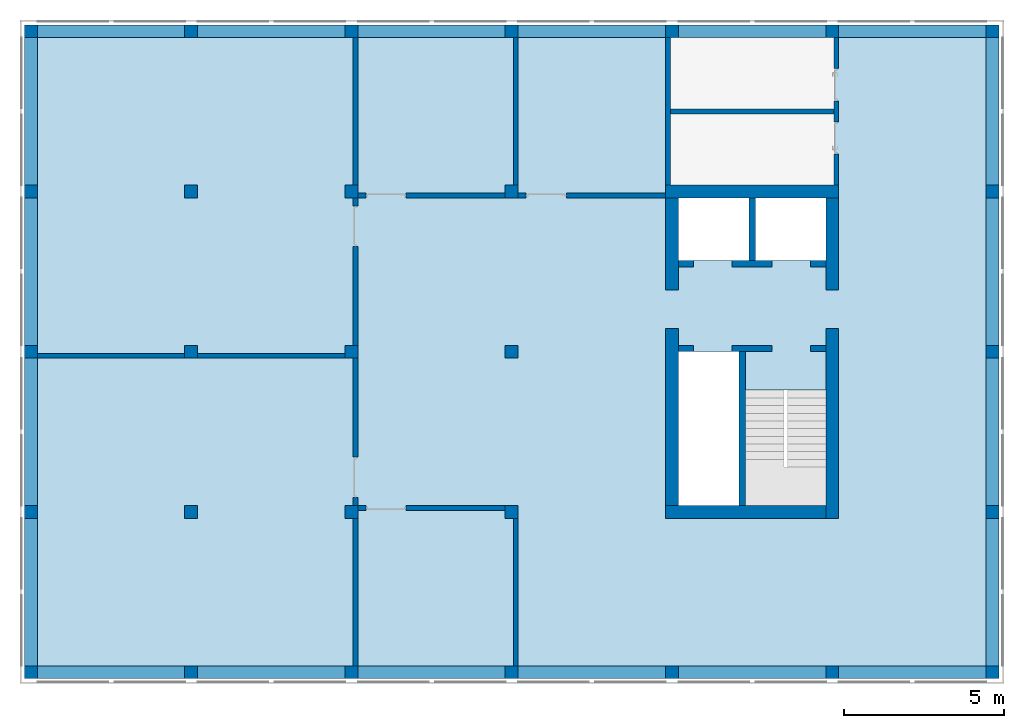
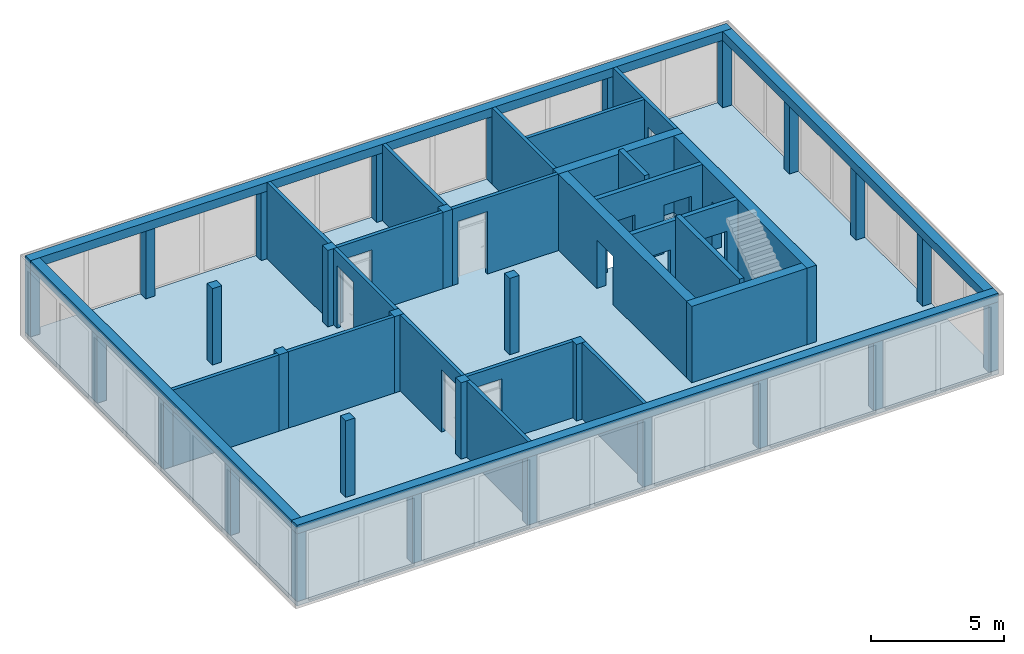
# One storey, part 1 of 6: 29 columns, 22 walls, 4 beams, 1 slab, 16 openings.
"""IFC2X3 building model written with IfcOpenShell, lengths in metres."""

import ifcopenshell
import ifcopenshell.guid

model = None  # the IFC model being written
_history = None  # IfcOwnerHistory: only IFC2X3 demands one
_inside = {}  # id of a spatial element -> (the spatial element, [elements in it])
_under = {}  # id of a project, library or spatial element -> (it, [spatial elements below it])
_declared = {}  # id of a project -> (the project, [libraries it declares])
_typed = {}  # id of a type object -> (the type object, [elements of that type])
_made_of = {}  # id of a material, layer set ... -> (it, [elements and type objects made of it])


def new_model(schema):
    """Start an empty IFC model of exactly this schema.

    Asked for "IFC4X3", IfcOpenShell would pick the latest addendum, in which some entities
    have other attributes; the version numbers below select the first issue.
    IFC2X3 requires an IfcOwnerHistory on every rooted entity: one is made here for all.
    """
    global model, _history
    if schema == "IFC4X3":
        model = ifcopenshell.file(schema_version=(4, 3, 0, 0))
    else:
        model = ifcopenshell.file(schema=schema)
    _inside.clear()
    _under.clear()
    _declared.clear()
    _typed.clear()
    _made_of.clear()
    _history = None
    if model.schema == "IFC2X3":
        org = make("IfcOrganization", Name="unknown")
        user = make(
            "IfcPersonAndOrganization",
            ThePerson=make("IfcPerson", FamilyName="unknown"),
            TheOrganization=org,
        )
        app = make(
            "IfcApplication",
            ApplicationDeveloper=org,
            Version="unknown",
            ApplicationFullName="unknown",
            ApplicationIdentifier="unknown",
        )
        _history = make(
            "IfcOwnerHistory",
            OwningUser=user,
            OwningApplication=app,
            ChangeAction="ADDED",
            CreationDate=0,
        )
    return model


def make(cls, **values):
    """One entity of the class cls with the attributes given. An attribute that is None is left unset."""
    return model.create_entity(
        cls, **{name: value for name, value in values.items() if value is not None}
    )


def entity(cls, *values):
    """Any entity or typed value of the class cls, its attributes in the order of the schema. None: left unset."""
    e = model.create_entity(cls)
    for i, value in enumerate(values):
        if value is not None:
            e[i] = value
    return e


def rooted(cls, **values):
    """An entity with a GlobalId (a new one), such as an element, a storey or a relation."""
    return make(cls, GlobalId=ifcopenshell.guid.new(), OwnerHistory=_history, **values)


def si_unit(unit_type, name, prefix=None):
    """IfcSIUnit, for example si_unit("LENGTHUNIT", "METRE", prefix="MILLI")."""
    return make("IfcSIUnit", UnitType=unit_type, Prefix=prefix, Name=name)


def converted_unit(unit_type, name, factor, base, dimensions=None, offset=None):
    """IfcConversionBasedUnit, such as the inch: factor (a typed value) times the base unit."""
    return make(
        "IfcConversionBasedUnit"
        if offset is None
        else "IfcConversionBasedUnitWithOffset",
        ConversionOffset=offset,
        Dimensions=None
        if dimensions is None
        else entity("IfcDimensionalExponents", *dimensions),
        UnitType=unit_type,
        Name=name,
        ConversionFactor=make(
            "IfcMeasureWithUnit", ValueComponent=factor, UnitComponent=base
        ),
    )


def assignment(units):
    """IfcUnitAssignment: the units of a project."""
    return None if units is None else make("IfcUnitAssignment", Units=units)


def point(xyz):
    """IfcCartesianPoint."""
    return None if xyz is None else make("IfcCartesianPoint", Coordinates=xyz)


def direction(xyz):
    """IfcDirection."""
    return None if xyz is None else make("IfcDirection", DirectionRatios=xyz)


def frame(location, z_axis=None, x_axis=None):
    """IfcAxis2Placement3D, a coordinate frame: its origin and axes. An axis left out is left unset."""
    return make(
        "IfcAxis2Placement3D",
        Location=point(location),
        Axis=direction(z_axis),
        RefDirection=direction(x_axis),
    )


def frame_2d(location, x_axis=None):
    """IfcAxis2Placement2D, a coordinate frame in the plane: its origin and x axis."""
    return make(
        "IfcAxis2Placement2D", Location=point(location), RefDirection=direction(x_axis)
    )


def origin():
    """The frame at (0, 0, 0) with its axes left unset."""
    return frame((0.0, 0.0, 0.0))


def origin_with_axes():
    """The frame at (0, 0, 0) with the z axis (0, 0, 1) and the x axis (1, 0, 0) written out."""
    return frame((0.0, 0.0, 0.0), z_axis=(0.0, 0.0, 1.0), x_axis=(1.0, 0.0, 0.0))


def place(relative_to, where):
    """IfcLocalPlacement: puts the frame where relative to a parent placement (None: the world)."""
    return make(
        "IfcLocalPlacement", PlacementRelTo=relative_to, RelativePlacement=where
    )


def context(
    kind, dimensions, precision=None, world=None, true_north=None, identifier=None
):
    """IfcGeometricRepresentationContext, for example the 3D "Model" context."""
    return make(
        "IfcGeometricRepresentationContext",
        ContextIdentifier=identifier,
        ContextType=kind,
        CoordinateSpaceDimension=dimensions,
        Precision=precision,
        WorldCoordinateSystem=world,
        TrueNorth=true_north,
    )


def subcontext(parent, identifier, kind, view, scale=None):
    """IfcGeometricRepresentationSubContext, for example "Body" below "Model"."""
    return make(
        "IfcGeometricRepresentationSubContext",
        ContextIdentifier=identifier,
        ContextType=kind,
        ParentContext=parent,
        TargetScale=scale,
        TargetView=view,
    )


def project(units=None, contexts=None):
    """IfcProject with its units and contexts."""
    return rooted(
        "IfcProject",
        Name="project",
        RepresentationContexts=contexts,
        UnitsInContext=assignment(units),
    )


def spatial(cls, under=None, at=None, **own):
    """A site, building, storey or space (cls), placed at a placement, below another one or the project."""
    s = rooted(cls, ObjectPlacement=at, **own)
    if under is not None:
        _under.setdefault(under.id(), (under, []))[1].append(s)
    return s


def polyline(points):
    """IfcPolyline through the points."""
    return make("IfcPolyline", Points=[point(p) for p in points])


def profile(cls, at=None, kind="AREA", **sizes):
    """A parametric profile (cls). Its sizes go by their IFC names, for example OverallWidth=200.0."""
    return make(cls, ProfileType=kind, Position=at, **sizes)


def rectangle(**sizes):
    """IfcRectangleProfileDef."""
    return profile("IfcRectangleProfileDef", **sizes)


def outline(outer, holes=None, kind="AREA"):
    """IfcArbitraryClosedProfileDef: a profile drawn as a closed curve; with holes, ...WithVoids."""
    if holes is None:
        return make("IfcArbitraryClosedProfileDef", ProfileType=kind, OuterCurve=outer)
    return make(
        "IfcArbitraryProfileDefWithVoids",
        ProfileType=kind,
        OuterCurve=outer,
        InnerCurves=holes,
    )


def extrude(swept, where, along, depth):
    """IfcExtrudedAreaSolid: the profile swept, set in the frame where, extruded along a direction by depth."""
    return make(
        "IfcExtrudedAreaSolid",
        SweptArea=swept,
        Position=where,
        ExtrudedDirection=direction(along),
        Depth=depth,
    )


def shape(context_of_items, identifier, shape_type, items):
    """IfcShapeRepresentation: the items that make up one representation, for example the "Body"."""
    return make(
        "IfcShapeRepresentation",
        ContextOfItems=context_of_items,
        RepresentationIdentifier=identifier,
        RepresentationType=shape_type,
        Items=items,
    )


def material(Name=None, Category=None):
    """IfcMaterial."""
    return make("IfcMaterial", Name=Name, Category=Category)


def layer(
    of_material, thickness, ventilated=None, Name=None, Category=None, Priority=None
):
    """IfcMaterialLayer: one layer of a wall or slab, of a material (None: an air gap)."""
    return make(
        "IfcMaterialLayer",
        Material=of_material,
        LayerThickness=thickness,
        IsVentilated=ventilated,
        Name=Name,
        Category=Category,
        Priority=Priority,
    )


def layer_set(layers, Name=None):
    """IfcMaterialLayerSet."""
    return make("IfcMaterialLayerSet", MaterialLayers=layers, LayerSetName=Name)


def layer_usage(for_layer_set, set_direction, sense, offset, extent=None):
    """IfcMaterialLayerSetUsage: how a layer set lies in its element."""
    return make(
        "IfcMaterialLayerSetUsage",
        ForLayerSet=for_layer_set,
        LayerSetDirection=set_direction,
        DirectionSense=sense,
        OffsetFromReferenceLine=offset,
        ReferenceExtent=extent,
    )


def made_of(thing, what):
    """Note that an element or type object is made of a material, layer set ...; save() writes the relation."""
    if what is not None:
        _made_of.setdefault(what.id(), (what, []))[1].append(thing)
    return thing


def element(
    cls,
    number,
    at=None,
    inside=None,
    cuts=None,
    type_object=None,
    material=None,
    context=None,
    identifier="Body",
    shape_type=None,
    held_by="IfcProductDefinitionShape",
    body=None,
    shapes=None,
    **own,
):
    """One element of the class cls, such as IfcWall. Its Tag is "e" and its number.

    at: its placement. inside: the storey or other place that contains it. cuts: it is an
    opening in that element (IfcRelVoidsElement). A single representation is given by context,
    identifier, shape_type and body (its items); several are given by shapes. held_by: the class
    of the entity that holds the representations. save() writes the other relations.
    """
    e = rooted(cls, Tag="e%d" % number, ObjectPlacement=at, **own)
    if body is not None:
        shapes = [shape(context, identifier, shape_type, body)]
    if shapes is not None:
        e.Representation = make(held_by, Representations=shapes)
    if inside is not None:
        _inside.setdefault(inside.id(), (inside, []))[1].append(e)
    if cuts is not None:
        rooted(
            "IfcRelVoidsElement", RelatingBuildingElement=cuts, RelatedOpeningElement=e
        )
    if type_object is not None:
        _typed.setdefault(type_object.id(), (type_object, []))[1].append(e)
    return made_of(e, material)


def aggregate(whole, parts):
    """IfcRelAggregates: a whole, such as a stair, and the parts it consists of."""
    return rooted("IfcRelAggregates", RelatingObject=whole, RelatedObjects=parts)


def save(model, path):
    """Write the relations noted so far, then the file.

    IfcRelAggregates (storeys below a building ...), IfcRelContainedInSpatialStructure (elements
    in a storey), IfcRelDefinesByType, IfcRelAssociatesMaterial and IfcRelDeclares: one each for
    every whole, place, type object, material and project.
    """
    for whole, parts in _under.values():
        aggregate(whole, parts)
    for where, things in _inside.values():
        rooted(
            "IfcRelContainedInSpatialStructure",
            RelatedElements=things,
            RelatingStructure=where,
        )
    for kind, things in _typed.values():
        rooted("IfcRelDefinesByType", RelatedObjects=things, RelatingType=kind)
    for what, things in _made_of.values():
        rooted("IfcRelAssociatesMaterial", RelatedObjects=things, RelatingMaterial=what)
    for by, libraries in _declared.values():
        rooted("IfcRelDeclares", RelatingContext=by, RelatedDefinitions=libraries)
    model.write(path)


model = new_model("IFC2X3")

# Units and contexts
model_context = context("Model", 3, precision=1e-05, world=origin())
body_context = subcontext(model_context, "Body", "Model", "MODEL_VIEW")
ifc_project = project(units=[si_unit("LENGTHUNIT", "METRE"), si_unit("AREAUNIT", "SQUARE_METRE"), si_unit("VOLUMEUNIT", "CUBIC_METRE"), si_unit("MASSUNIT", "GRAM", prefix="KILO"), converted_unit("PLANEANGLEUNIT", "DEGREE", entity("IfcPlaneAngleMeasure", 0.0174532925199433), si_unit("PLANEANGLEUNIT", "RADIAN"), dimensions=[0, 0, 0, 0, 0, 0, 0])], contexts=[model_context])

# Site, building, storey
site_placement = place(None, origin())
site = spatial("IfcSite", under=ifc_project, at=site_placement, CompositionType="ELEMENT")
building_placement = place(site_placement, origin())
building = spatial("IfcBuilding", under=site, at=building_placement, CompositionType="ELEMENT")
storey_placement = place(building_placement, frame((0.0, 0.0, 8.6)))
storey = spatial("IfcBuildingStorey", under=building, at=storey_placement, Name="2. Obergeschoss", CompositionType="ELEMENT", Elevation=8.6)

# Columns
ifc_material_1 = material(Name="C30/37")
column_1_placement = place(storey_placement, frame((5.0, 5.0, 0.0)))
element("IfcColumn", 1, at=column_1_placement, inside=storey, material=ifc_material_1, context=body_context, shape_type="SweptSolid", body=[
    extrude(rectangle(XDim=0.4, YDim=0.4, at=frame_2d((0.2, 0.2), x_axis=(1.0, 0.0))), origin_with_axes(), (0.0, 0.0, 1.0), 3.5),
])
ifc_material_2 = material(Name="C30/37")
column_2_placement = place(storey_placement, frame((10.0, 5.0, 0.0)))
element("IfcColumn", 2, at=column_2_placement, inside=storey, material=ifc_material_2, context=body_context, shape_type="SweptSolid", body=[
    extrude(rectangle(XDim=0.4, YDim=0.4, at=frame_2d((0.2, 0.2), x_axis=(1.0, 0.0))), origin_with_axes(), (0.0, 0.0, 1.0), 3.5),
])
ifc_material_3 = material(Name="C30/37")
column_3_placement = place(storey_placement, frame((5.0, 10.0, 0.0)))
element("IfcColumn", 3, at=column_3_placement, inside=storey, material=ifc_material_3, context=body_context, shape_type="SweptSolid", body=[
    extrude(rectangle(XDim=0.4, YDim=0.4, at=frame_2d((0.2, 0.2), x_axis=(1.0, 0.0))), origin_with_axes(), (0.0, 0.0, 1.0), 3.5),
])
ifc_material_4 = material(Name="C30/37")
column_4_placement = place(storey_placement, frame((10.0, 10.0, 0.0)))
element("IfcColumn", 4, at=column_4_placement, inside=storey, material=ifc_material_4, context=body_context, shape_type="SweptSolid", body=[
    extrude(rectangle(XDim=0.4, YDim=0.4, at=frame_2d((0.2, 0.2), x_axis=(1.0, 0.0))), origin_with_axes(), (0.0, 0.0, 1.0), 3.5),
])
ifc_material_5 = material(Name="C30/37")
column_5_placement = place(storey_placement, frame((15.0, 10.0, 0.0)))
element("IfcColumn", 5, at=column_5_placement, inside=storey, material=ifc_material_5, context=body_context, shape_type="SweptSolid", body=[
    extrude(rectangle(XDim=0.4, YDim=0.4, at=frame_2d((0.2, 0.2), x_axis=(1.0, 0.0))), origin_with_axes(), (0.0, 0.0, 1.0), 3.5),
])
ifc_material_6 = material(Name="C30/37")
column_6_placement = place(storey_placement, frame((5.0, 15.0, 0.0)))
element("IfcColumn", 6, at=column_6_placement, inside=storey, material=ifc_material_6, context=body_context, shape_type="SweptSolid", body=[
    extrude(rectangle(XDim=0.4, YDim=0.4, at=frame_2d((0.2, 0.2), x_axis=(1.0, 0.0))), origin_with_axes(), (0.0, 0.0, 1.0), 3.5),
])
ifc_material_7 = material(Name="C30/37")
column_7_placement = place(storey_placement, frame((10.0, 15.0, 0.0)))
element("IfcColumn", 7, at=column_7_placement, inside=storey, material=ifc_material_7, context=body_context, shape_type="SweptSolid", body=[
    extrude(rectangle(XDim=0.4, YDim=0.4, at=frame_2d((0.2, 0.2), x_axis=(1.0, 0.0))), origin_with_axes(), (0.0, 0.0, 1.0), 3.5),
])
ifc_material_8 = material(Name="C30/37")
column_8_placement = place(storey_placement, frame((15.0, 15.0, 0.0)))
element("IfcColumn", 8, at=column_8_placement, inside=storey, material=ifc_material_8, context=body_context, shape_type="SweptSolid", body=[
    extrude(rectangle(XDim=0.4, YDim=0.4, at=frame_2d((0.2, 0.2), x_axis=(1.0, 0.0))), origin_with_axes(), (0.0, 0.0, 1.0), 3.5),
])
ifc_material_9 = material(Name="C30/37")
column_9_placement = place(storey_placement, frame((15.0, 5.0, 0.0)))
element("IfcColumn", 9, at=column_9_placement, inside=storey, material=ifc_material_9, context=body_context, shape_type="SweptSolid", body=[
    extrude(rectangle(XDim=0.4, YDim=0.4, at=frame_2d((0.2, 0.2), x_axis=(1.0, 0.0))), origin_with_axes(), (0.0, 0.0, 1.0), 3.5),
])
ifc_material_10 = material(Name="C30/37")
column_10_placement = place(storey_placement, frame((30.0, 5.0, 0.0)))
element("IfcColumn", 10, at=column_10_placement, inside=storey, material=ifc_material_10, context=body_context, shape_type="SweptSolid", body=[
    extrude(rectangle(XDim=0.4, YDim=0.4, at=frame_2d((0.2, 0.2), x_axis=(1.0, 0.0))), origin_with_axes(), (0.0, 0.0, 1.0), 3.1),
])
ifc_material_11 = material(Name="C30/37")
column_11_placement = place(storey_placement, frame((30.0, 10.0, 0.0)))
element("IfcColumn", 11, at=column_11_placement, inside=storey, material=ifc_material_11, context=body_context, shape_type="SweptSolid", body=[
    extrude(rectangle(XDim=0.4, YDim=0.4, at=frame_2d((0.2, 0.2), x_axis=(1.0, 0.0))), origin_with_axes(), (0.0, 0.0, 1.0), 3.1),
])
ifc_material_12 = material(Name="C30/37")
column_12_placement = place(storey_placement, frame((30.0, 15.0, 0.0)))
element("IfcColumn", 12, at=column_12_placement, inside=storey, material=ifc_material_12, context=body_context, shape_type="SweptSolid", body=[
    extrude(rectangle(XDim=0.4, YDim=0.4, at=frame_2d((0.2, 0.2), x_axis=(1.0, 0.0))), origin_with_axes(), (0.0, 0.0, 1.0), 3.1),
])
ifc_material_13 = material(Name="C30/37")
column_13_placement = place(storey_placement, frame((30.0, 20.0, 0.0)))
element("IfcColumn", 13, at=column_13_placement, inside=storey, material=ifc_material_13, context=body_context, shape_type="SweptSolid", body=[
    extrude(rectangle(XDim=0.4, YDim=0.4, at=frame_2d((0.2, 0.2), x_axis=(1.0, 0.0))), origin_with_axes(), (0.0, 0.0, 1.0), 3.1),
])
ifc_material_14 = material(Name="C30/37")
column_14_placement = place(storey_placement, frame((30.0, -2.8421709430404e-17, 0.0)))
element("IfcColumn", 14, at=column_14_placement, inside=storey, material=ifc_material_14, context=body_context, shape_type="SweptSolid", body=[
    extrude(rectangle(XDim=0.4, YDim=0.4, at=frame_2d((0.2, 0.2), x_axis=(1.0, 0.0))), origin_with_axes(), (0.0, 0.0, 1.0), 3.1),
])
ifc_material_15 = material(Name="C30/37")
column_15_placement = place(storey_placement, frame((25.0, 20.0, 0.0)))
element("IfcColumn", 15, at=column_15_placement, inside=storey, material=ifc_material_15, context=body_context, shape_type="SweptSolid", body=[
    extrude(rectangle(XDim=0.4, YDim=0.4, at=frame_2d((0.2, 0.2), x_axis=(1.0, 0.0))), origin_with_axes(), (0.0, 0.0, 1.0), 3.1),
])
ifc_material_16 = material(Name="C30/37")
column_16_placement = place(storey_placement, frame((5.0, 20.0, 0.0)))
element("IfcColumn", 16, at=column_16_placement, inside=storey, material=ifc_material_16, context=body_context, shape_type="SweptSolid", body=[
    extrude(rectangle(XDim=0.4, YDim=0.4, at=frame_2d((0.2, 0.2), x_axis=(1.0, 0.0))), origin_with_axes(), (0.0, 0.0, 1.0), 3.1),
])
ifc_material_17 = material(Name="C30/37")
column_17_placement = place(storey_placement, frame((10.0, 20.0, 0.0)))
element("IfcColumn", 17, at=column_17_placement, inside=storey, material=ifc_material_17, context=body_context, shape_type="SweptSolid", body=[
    extrude(rectangle(XDim=0.4, YDim=0.4, at=frame_2d((0.2, 0.2), x_axis=(1.0, 0.0))), origin_with_axes(), (0.0, 0.0, 1.0), 3.1),
])
ifc_material_18 = material(Name="C30/37")
column_18_placement = place(storey_placement, frame((15.0, 20.0, 0.0)))
element("IfcColumn", 18, at=column_18_placement, inside=storey, material=ifc_material_18, context=body_context, shape_type="SweptSolid", body=[
    extrude(rectangle(XDim=0.4, YDim=0.4, at=frame_2d((0.2, 0.2), x_axis=(1.0, 0.0))), origin_with_axes(), (0.0, 0.0, 1.0), 3.1),
])
ifc_material_19 = material(Name="C30/37")
column_19_placement = place(storey_placement, frame((20.0, 20.0, 0.0)))
element("IfcColumn", 19, at=column_19_placement, inside=storey, material=ifc_material_19, context=body_context, shape_type="SweptSolid", body=[
    extrude(rectangle(XDim=0.4, YDim=0.4, at=frame_2d((0.2, 0.2), x_axis=(1.0, 0.0))), origin_with_axes(), (0.0, 0.0, 1.0), 3.1),
])
ifc_material_20 = material(Name="C30/37")
column_20_placement = place(storey_placement, frame((0.0, 20.0, 0.0)))
element("IfcColumn", 20, at=column_20_placement, inside=storey, material=ifc_material_20, context=body_context, shape_type="SweptSolid", body=[
    extrude(rectangle(XDim=0.4, YDim=0.4, at=frame_2d((0.2, 0.2), x_axis=(1.0, 0.0))), origin_with_axes(), (0.0, 0.0, 1.0), 3.1),
])
ifc_material_21 = material(Name="C30/37")
column_21_placement = place(storey_placement, frame((0.0, 5.0, 0.0)))
element("IfcColumn", 21, at=column_21_placement, inside=storey, material=ifc_material_21, context=body_context, shape_type="SweptSolid", body=[
    extrude(rectangle(XDim=0.4, YDim=0.4, at=frame_2d((0.2, 0.2), x_axis=(1.0, 0.0))), origin_with_axes(), (0.0, 0.0, 1.0), 3.1),
])
ifc_material_22 = material(Name="C30/37")
column_22_placement = place(storey_placement, frame((0.0, 10.0, 0.0)))
element("IfcColumn", 22, at=column_22_placement, inside=storey, material=ifc_material_22, context=body_context, shape_type="SweptSolid", body=[
    extrude(rectangle(XDim=0.4, YDim=0.4, at=frame_2d((0.2, 0.2), x_axis=(1.0, 0.0))), origin_with_axes(), (0.0, 0.0, 1.0), 3.1),
])
ifc_material_23 = material(Name="C30/37")
column_23_placement = place(storey_placement, frame((0.0, 15.0, 0.0)))
element("IfcColumn", 23, at=column_23_placement, inside=storey, material=ifc_material_23, context=body_context, shape_type="SweptSolid", body=[
    extrude(rectangle(XDim=0.4, YDim=0.4, at=frame_2d((0.2, 0.2), x_axis=(1.0, 0.0))), origin_with_axes(), (0.0, 0.0, 1.0), 3.1),
])
ifc_material_24 = material(Name="C30/37")
column_24_placement = place(storey_placement, origin())
element("IfcColumn", 24, at=column_24_placement, inside=storey, material=ifc_material_24, context=body_context, shape_type="SweptSolid", body=[
    extrude(rectangle(XDim=0.4, YDim=0.4, at=frame_2d((0.2, 0.2), x_axis=(1.0, 0.0))), origin_with_axes(), (0.0, 0.0, 1.0), 3.1),
])
ifc_material_25 = material(Name="C30/37")
column_25_placement = place(storey_placement, frame((5.0, 0.0, 0.0)))
element("IfcColumn", 25, at=column_25_placement, inside=storey, material=ifc_material_25, context=body_context, shape_type="SweptSolid", body=[
    extrude(rectangle(XDim=0.4, YDim=0.4, at=frame_2d((0.2, 0.2), x_axis=(1.0, 0.0))), origin_with_axes(), (0.0, 0.0, 1.0), 3.1),
])
ifc_material_26 = material(Name="C30/37")
column_26_placement = place(storey_placement, frame((10.0, 0.0, 0.0)))
element("IfcColumn", 26, at=column_26_placement, inside=storey, material=ifc_material_26, context=body_context, shape_type="SweptSolid", body=[
    extrude(rectangle(XDim=0.4, YDim=0.4, at=frame_2d((0.2, 0.2), x_axis=(1.0, 0.0))), origin_with_axes(), (0.0, 0.0, 1.0), 3.1),
])
ifc_material_27 = material(Name="C30/37")
column_27_placement = place(storey_placement, frame((15.0, 0.0, 0.0)))
element("IfcColumn", 27, at=column_27_placement, inside=storey, material=ifc_material_27, context=body_context, shape_type="SweptSolid", body=[
    extrude(rectangle(XDim=0.4, YDim=0.4, at=frame_2d((0.2, 0.2), x_axis=(1.0, 0.0))), origin_with_axes(), (0.0, 0.0, 1.0), 3.1),
])
ifc_material_28 = material(Name="C30/37")
column_28_placement = place(storey_placement, frame((20.0, 0.0, 0.0)))
element("IfcColumn", 28, at=column_28_placement, inside=storey, material=ifc_material_28, context=body_context, shape_type="SweptSolid", body=[
    extrude(rectangle(XDim=0.4, YDim=0.4, at=frame_2d((0.2, 0.2), x_axis=(1.0, 0.0))), origin_with_axes(), (0.0, 0.0, 1.0), 3.1),
])
ifc_material_29 = material(Name="C30/37")
column_29_placement = place(storey_placement, frame((25.0, 0.0, 0.0)))
element("IfcColumn", 29, at=column_29_placement, inside=storey, material=ifc_material_29, context=body_context, shape_type="SweptSolid", body=[
    extrude(rectangle(XDim=0.4, YDim=0.4, at=frame_2d((0.2, 0.2), x_axis=(1.0, 0.0))), origin_with_axes(), (0.0, 0.0, 1.0), 3.1),
])

# Beams
ifc_material_30 = material(Name="C30/37")
beam_1_placement = place(storey_placement, frame((-2.8421709430404e-17, 20.0, 3.1)))
element("IfcBeam", 30, at=beam_1_placement, inside=storey, material=ifc_material_30, context=body_context, shape_type="SweptSolid", body=[
    extrude(rectangle(XDim=0.4, YDim=0.4, at=frame_2d((0.2, 0.2), x_axis=(1.0, 0.0))), frame((0.0, 0.0, 0.0), z_axis=(1.0, 0.0, 0.0), x_axis=(0.0, 1.0, 0.0)), (0.0, 0.0, 1.0), 30.4),
])
ifc_material_31 = material(Name="C30/37")
beam_2_placement = place(storey_placement, frame((2.95817792030736e-17, 2.8421709430404e-17, 3.1), z_axis=(0.0, 0.0, 1.0), x_axis=(1.0, -1.86984930463184e-18, 0.0)))
element("IfcBeam", 31, at=beam_2_placement, inside=storey, material=ifc_material_31, context=body_context, shape_type="SweptSolid", body=[
    extrude(rectangle(XDim=0.4, YDim=0.4, at=frame_2d((0.2, 0.2), x_axis=(1.0, 0.0))), frame((0.0, 0.0, 0.0), z_axis=(1.0, 0.0, 0.0), x_axis=(0.0, 1.0, 0.0)), (0.0, 0.0, 1.0), 30.4),
])
ifc_material_32 = material(Name="C30/37")
beam_3_placement = place(storey_placement, frame((30.4, 0.4, 3.1), z_axis=(0.0, 0.0, 1.0), x_axis=(0.0, 1.0, 0.0)))
element("IfcBeam", 32, at=beam_3_placement, inside=storey, material=ifc_material_32, context=body_context, shape_type="SweptSolid", body=[
    extrude(rectangle(XDim=0.4, YDim=0.4, at=frame_2d((0.2, 0.2), x_axis=(1.0, 0.0))), frame((0.0, 0.0, 0.0), z_axis=(1.0, 0.0, 0.0), x_axis=(0.0, 1.0, 0.0)), (0.0, 0.0, 1.0), 19.6),
])
ifc_material_33 = material(Name="C30/37")
beam_4_placement = place(storey_placement, frame((-2.8421709430404e-17, 20.0, 3.1), z_axis=(0.0, 0.0, 1.0), x_axis=(2.90017443167388e-18, -1.0, 0.0)))
element("IfcBeam", 33, at=beam_4_placement, inside=storey, material=ifc_material_33, context=body_context, shape_type="SweptSolid", body=[
    extrude(rectangle(XDim=0.4, YDim=0.4, at=frame_2d((0.2, 0.2), x_axis=(1.0, 0.0))), frame((0.0, 0.0, 0.0), z_axis=(1.0, 0.0, 0.0), x_axis=(0.0, 1.0, 0.0)), (0.0, 0.0, 1.0), 19.6),
])

# Slab, openings
ifc_material_34 = material(Name="C25/30")
slab_placement = place(storey_placement, frame((0.0, 0.0, -0.2)))
slab = element("IfcSlab", 34, at=slab_placement, inside=storey, material=ifc_material_34, Name="Geschossdecke", PredefinedType="FLOOR", context=body_context, shape_type="SweptSolid", body=[
    extrude(rectangle(XDim=30.4, YDim=20.4, at=frame_2d((15.2, 10.2), x_axis=(1.0, 0.0))), origin_with_axes(), (0.0, 0.0, 1.0), 0.2),
])
opening_1_placement = place(slab_placement, frame((22.5, 5.4, 0.0)))
element("IfcOpeningElement", 35, at=opening_1_placement, cuts=slab, ObjectType="Opening", context=body_context, shape_type="SweptSolid", body=[
    extrude(rectangle(XDim=3.6, YDim=2.5, at=frame_2d((0.0, 0.0), x_axis=(0.0, -1.0))), frame((1.25, 1.8, 0.0), z_axis=(0.0, 0.0, 1.0), x_axis=(1.0, 0.0, 0.0)), (0.0, 0.0, 1.0), 0.2),
])
opening_2_placement = place(slab_placement, frame((20.4, 5.4, 0.0)))
element("IfcOpeningElement", 36, at=opening_2_placement, cuts=slab, ObjectType="Opening", context=body_context, shape_type="SweptSolid", body=[
    extrude(rectangle(XDim=2.1, YDim=4.8, at=frame_2d((1.81898940354586e-15, 0.0), x_axis=(-1.0, 0.0))), frame((1.05, 2.4, 0.0), z_axis=(0.0, 0.0, 1.0), x_axis=(1.0, 0.0, 0.0)), (0.0, 0.0, 1.0), 0.2),
])
opening_3_placement = place(slab_placement, frame((20.4, 13.05, 0.0)))
element("IfcOpeningElement", 37, at=opening_3_placement, cuts=slab, ObjectType="Opening", context=body_context, shape_type="SweptSolid", body=[
    extrude(rectangle(XDim=1.95, YDim=4.6, at=frame_2d((1.81898940354586e-15, 0.0), x_axis=(0.0, -1.0))), frame((2.3, 0.975, 0.0), z_axis=(0.0, 0.0, 1.0), x_axis=(1.0, 0.0, 0.0)), (0.0, 0.0, 1.0), 0.2),
])

# Wall
ifc_material_35 = material(Name="C25/30")
ifc_layer_1 = layer(ifc_material_35, 0.2)
ifc_layer_set_1 = layer_set([ifc_layer_1])
ifc_layer_usage_1 = layer_usage(ifc_layer_set_1, "AXIS2", "POSITIVE", -0.2)
wall_1_placement = place(storey_placement, frame((22.3, 10.2, 0.0), z_axis=(0.0, 0.0, 1.0), x_axis=(0.0, -1.0, 0.0)))
element("IfcWallStandardCase", 38, at=wall_1_placement, inside=storey, material=ifc_layer_usage_1, Name="IW Beton", context=body_context, shape_type="SweptSolid", body=[
    extrude(rectangle(XDim=4.8, YDim=0.2, at=frame_2d((2.4, 0.1), x_axis=(1.0, 0.0))), origin_with_axes(), (0.0, 0.0, 1.0), 3.7),
])

# Wall, openings
ifc_material_36 = material(Name="C25/30")
ifc_layer_2 = layer(ifc_material_36, 0.2)
ifc_layer_set_2 = layer_set([ifc_layer_2])
ifc_layer_usage_2 = layer_usage(ifc_layer_set_2, "AXIS2", "POSITIVE", -0.2)
wall_2_placement = place(storey_placement, frame((25.0, 10.4, 0.0), z_axis=(0.0, 0.0, 1.0), x_axis=(-1.0, 0.0, 0.0)))
wall_2 = element("IfcWallStandardCase", 39, at=wall_2_placement, inside=storey, material=ifc_layer_usage_2, Name="IW Beton", context=body_context, shape_type="SweptSolid", body=[
    extrude(rectangle(XDim=4.6, YDim=0.2, at=frame_2d((2.3, 0.1), x_axis=(1.0, 0.0))), origin_with_axes(), (0.0, 0.0, 1.0), 3.5),
])
opening_4_placement = place(wall_2_placement, frame((1.68, 0.2, 0.0), z_axis=(0.0, -1.0, 0.0), x_axis=(0.0, 0.0, 1.0)))
element("IfcOpeningElement", 40, at=opening_4_placement, cuts=wall_2, ObjectType="Opening", context=body_context, shape_type="SweptSolid", body=[
    extrude(outline(polyline([(0.0, 1.21), (2.21, 1.21), (2.21, 0.0), (0.0, 0.0), (0.0, 1.21)])), origin_with_axes(), (0.0, 0.0, 1.0), 0.2),
])
opening_5_placement = place(wall_2_placement, frame((4.13, 0.2, 0.0), z_axis=(0.0, -1.0, 0.0), x_axis=(0.0, 0.0, 1.0)))
element("IfcOpeningElement", 41, at=opening_5_placement, cuts=wall_2, ObjectType="Opening", context=body_context, shape_type="SweptSolid", body=[
    extrude(outline(polyline([(0.0, 1.21), (2.21, 1.21), (2.21, 0.0), (0.0, 0.0), (0.0, 1.21)])), origin_with_axes(), (0.0, 0.0, 1.0), 0.2),
])

ifc_material_37 = material(Name="C25/30")
ifc_layer_3 = layer(ifc_material_37, 0.2)
ifc_layer_set_3 = layer_set([ifc_layer_3])
ifc_layer_usage_3 = layer_usage(ifc_layer_set_3, "AXIS2", "POSITIVE", -0.2)
wall_3_placement = place(storey_placement, frame((25.0, 13.05, 0.0), z_axis=(0.0, 0.0, 1.0), x_axis=(-1.0, 0.0, 0.0)))
wall_3 = element("IfcWallStandardCase", 42, at=wall_3_placement, inside=storey, material=ifc_layer_usage_3, Name="IW Beton", context=body_context, shape_type="SweptSolid", body=[
    extrude(rectangle(XDim=4.6, YDim=0.2, at=frame_2d((2.3, 0.1), x_axis=(1.0, 0.0))), origin_with_axes(), (0.0, 0.0, 1.0), 3.5),
])
opening_6_placement = place(wall_3_placement, frame((1.68, 0.2, 0.0), z_axis=(0.0, -1.0, 0.0), x_axis=(0.0, 0.0, 1.0)))
element("IfcOpeningElement", 43, at=opening_6_placement, cuts=wall_3, ObjectType="Opening", context=body_context, shape_type="SweptSolid", body=[
    extrude(outline(polyline([(0.0, 1.21), (2.21, 1.21), (2.21, 0.0), (0.0, 0.0), (0.0, 1.21)])), origin_with_axes(), (0.0, 0.0, 1.0), 0.2),
])
opening_7_placement = place(wall_3_placement, frame((4.13, 0.2, 0.0), z_axis=(0.0, -1.0, 0.0), x_axis=(0.0, 0.0, 1.0)))
element("IfcOpeningElement", 44, at=opening_7_placement, cuts=wall_3, ObjectType="Opening", context=body_context, shape_type="SweptSolid", body=[
    extrude(outline(polyline([(0.0, 1.21), (2.21, 1.21), (2.21, 0.0), (0.0, 0.0), (0.0, 1.21)])), origin_with_axes(), (0.0, 0.0, 1.0), 0.2),
])

# Wall
ifc_material_38 = material(Name="C25/30")
ifc_layer_4 = layer(ifc_material_38, 0.2)
ifc_layer_set_4 = layer_set([ifc_layer_4])
ifc_layer_usage_4 = layer_usage(ifc_layer_set_4, "AXIS2", "POSITIVE", -0.2)
wall_4_placement = place(storey_placement, frame((22.6, 15.0, 0.0), z_axis=(0.0, 0.0, 1.0), x_axis=(0.0, -1.0, 0.0)))
element("IfcWallStandardCase", 45, at=wall_4_placement, inside=storey, material=ifc_layer_usage_4, Name="IW Beton", context=body_context, shape_type="SweptSolid", body=[
    extrude(rectangle(XDim=1.95, YDim=0.2, at=frame_2d((0.975, 0.1), x_axis=(1.0, 0.0))), origin_with_axes(), (0.0, 0.0, 1.0), 3.7),
])

# Wall, opening
ifc_material_39 = material(Name="C25/30")
ifc_layer_5 = layer(ifc_material_39, 0.4)
ifc_layer_set_5 = layer_set([ifc_layer_5])
ifc_layer_usage_5 = layer_usage(ifc_layer_set_5, "AXIS2", "POSITIVE", -0.2)
wall_5_placement = place(storey_placement, frame((25.0, 15.0, 0.0), z_axis=(0.0, 0.0, 1.0), x_axis=(0.0, -1.0, 0.0)))
wall_5 = element("IfcWallStandardCase", 46, at=wall_5_placement, inside=storey, material=ifc_layer_usage_5, context=body_context, shape_type="SweptSolid", body=[
    extrude(rectangle(XDim=10.0, YDim=0.4, at=frame_2d((5.0, 0.2), x_axis=(1.0, 0.0))), origin_with_axes(), (0.0, 0.0, 1.0), 3.5),
])
opening_8_placement = place(wall_5_placement, frame((2.87, 0.0, 0.0), z_axis=(0.0, 1.0, 0.0), x_axis=(0.0, 0.0, 1.0)))
element("IfcOpeningElement", 47, at=opening_8_placement, cuts=wall_5, ObjectType="Opening", context=body_context, shape_type="SweptSolid", body=[
    extrude(outline(polyline([(0.0, 1.21), (2.21, 1.21), (2.21, 0.0), (0.0, 0.0), (0.0, 1.21)])), origin_with_axes(), (0.0, 0.0, 1.0), 0.4),
])

# Wall
ifc_material_40 = material(Name="C25/30")
ifc_layer_6 = layer(ifc_material_40, 0.4)
ifc_layer_set_6 = layer_set([ifc_layer_6])
ifc_layer_usage_6 = layer_usage(ifc_layer_set_6, "AXIS2", "POSITIVE", -0.2)
wall_6_placement = place(storey_placement, frame((20.0, 15.0, 0.0)))
element("IfcWallStandardCase", 48, at=wall_6_placement, inside=storey, material=ifc_layer_usage_6, context=body_context, shape_type="SweptSolid", body=[
    extrude(rectangle(XDim=5.4, YDim=0.4, at=frame_2d((2.7, 0.2), x_axis=(1.0, 0.0))), origin_with_axes(), (0.0, 0.0, 1.0), 3.5),
])

# Wall, opening
ifc_material_41 = material(Name="C25/30")
ifc_layer_7 = layer(ifc_material_41, 0.4)
ifc_layer_set_7 = layer_set([ifc_layer_7])
ifc_layer_usage_7 = layer_usage(ifc_layer_set_7, "AXIS2", "POSITIVE", -0.2)
wall_7_placement = place(storey_placement, frame((20.4, 5.4, 0.0), z_axis=(0.0, 0.0, 1.0), x_axis=(0.0, 1.0, 0.0)))
wall_7 = element("IfcWallStandardCase", 49, at=wall_7_placement, inside=storey, material=ifc_layer_usage_7, context=body_context, shape_type="SweptSolid", body=[
    extrude(rectangle(XDim=9.6, YDim=0.4, at=frame_2d((4.8, 0.2), x_axis=(1.0, 0.0))), origin_with_axes(), (0.0, 0.0, 1.0), 3.5),
])
opening_9_placement = place(wall_7_placement, frame((5.52, 0.0, 0.0), z_axis=(0.0, 1.0, 0.0), x_axis=(0.0, 0.0, 1.0)))
element("IfcOpeningElement", 50, at=opening_9_placement, cuts=wall_7, ObjectType="Opening", context=body_context, shape_type="SweptSolid", body=[
    extrude(outline(polyline([(0.0, 1.21), (2.21, 1.21), (2.21, 0.0), (0.0, 0.0), (0.0, 1.21)])), origin_with_axes(), (0.0, 0.0, 1.0), 0.4),
])

# Wall
ifc_material_42 = material(Name="C25/30")
ifc_layer_8 = layer(ifc_material_42, 0.4)
ifc_layer_set_8 = layer_set([ifc_layer_8])
ifc_layer_usage_8 = layer_usage(ifc_layer_set_8, "AXIS2", "POSITIVE", -0.2)
wall_8_placement = place(storey_placement, frame((25.0, 5.4, 0.0), z_axis=(0.0, 0.0, 1.0), x_axis=(-1.0, 0.0, 0.0)))
element("IfcWallStandardCase", 51, at=wall_8_placement, inside=storey, material=ifc_layer_usage_8, context=body_context, shape_type="SweptSolid", body=[
    extrude(rectangle(XDim=5.0, YDim=0.4, at=frame_2d((2.5, 0.2), x_axis=(1.0, 0.0))), origin_with_axes(), (0.0, 0.0, 1.0), 3.5),
])

# Wall, opening
ifc_material_43 = material()
ifc_layer_9 = layer(ifc_material_43, 0.15)
ifc_layer_set_9 = layer_set([ifc_layer_9])
ifc_layer_usage_9 = layer_usage(ifc_layer_set_9, "AXIS2", "POSITIVE", -0.15)
wall_9_placement = place(storey_placement, frame((10.4, 5.25, 0.0)))
wall_9 = element("IfcWallStandardCase", 52, at=wall_9_placement, inside=storey, material=ifc_layer_usage_9, context=body_context, shape_type="SweptSolid", body=[
    extrude(rectangle(XDim=4.6, YDim=0.15, at=frame_2d((2.3, 0.075), x_axis=(1.0, 0.0))), origin_with_axes(), (0.0, 0.0, 1.0), 3.5),
])
opening_10_placement = place(wall_9_placement, frame((1.51, 0.15, 0.0), z_axis=(0.0, -1.0, 0.0), x_axis=(0.0, 0.0, 1.0)))
element("IfcOpeningElement", 53, at=opening_10_placement, cuts=wall_9, ObjectType="Opening", context=body_context, shape_type="SweptSolid", body=[
    extrude(outline(polyline([(0.0, 1.26), (2.86, 1.26), (2.86, 0.0), (0.0, 0.0), (0.0, 1.26)])), origin_with_axes(), (0.0, 0.0, 1.0), 0.15),
])

# Wall
ifc_material_44 = material()
ifc_layer_10 = layer(ifc_material_44, 0.150000000000002)
ifc_layer_set_10 = layer_set([ifc_layer_10])
ifc_layer_usage_10 = layer_usage(ifc_layer_set_10, "AXIS2", "POSITIVE", -0.15)
wall_10_placement = place(storey_placement, frame((15.25, 5.0, 0.0), z_axis=(0.0, 0.0, 1.0), x_axis=(0.0, -1.0, 0.0)))
element("IfcWallStandardCase", 54, at=wall_10_placement, inside=storey, material=ifc_layer_usage_10, context=body_context, shape_type="SweptSolid", body=[
    extrude(rectangle(XDim=4.6, YDim=0.150000000000002, at=frame_2d((2.3, 0.0750000000000009), x_axis=(1.0, 0.0))), origin_with_axes(), (0.0, 0.0, 1.0), 3.5),
])

# Wall, opening
ifc_material_45 = material()
ifc_layer_11 = layer(ifc_material_45, 0.15)
ifc_layer_set_11 = layer_set([ifc_layer_11])
ifc_layer_usage_11 = layer_usage(ifc_layer_set_11, "AXIS2", "POSITIVE", -0.15)
wall_11_placement = place(storey_placement, frame((10.25, 10.0, 0.0), z_axis=(0.0, 0.0, 1.0), x_axis=(0.0, -1.0, 0.0)))
wall_11 = element("IfcWallStandardCase", 55, at=wall_11_placement, inside=storey, material=ifc_layer_usage_11, context=body_context, shape_type="SweptSolid", body=[
    extrude(rectangle(XDim=4.6, YDim=0.15, at=frame_2d((2.3, 0.075), x_axis=(1.0, 0.0))), origin_with_axes(), (0.0, 0.0, 1.0), 3.5),
])
opening_11_placement = place(wall_11_placement, frame((4.35, 0.15, 0.0), z_axis=(0.0, -1.0, 0.0), x_axis=(0.0, 0.0, 1.0)))
element("IfcOpeningElement", 56, at=opening_11_placement, cuts=wall_11, ObjectType="Opening", context=body_context, shape_type="SweptSolid", body=[
    extrude(outline(polyline([(0.0, 1.26), (2.86, 1.26), (2.86, 0.0), (0.0, 0.0), (0.0, 1.26)])), origin_with_axes(), (0.0, 0.0, 1.0), 0.15),
])

ifc_material_46 = material()
ifc_layer_12 = layer(ifc_material_46, 0.15)
ifc_layer_set_12 = layer_set([ifc_layer_12])
ifc_layer_usage_12 = layer_usage(ifc_layer_set_12, "AXIS2", "POSITIVE", -0.15)
wall_12_placement = place(storey_placement, frame((10.25, 15.0, 0.0), z_axis=(0.0, 0.0, 1.0), x_axis=(0.0, -1.0, 0.0)))
wall_12 = element("IfcWallStandardCase", 57, at=wall_12_placement, inside=storey, material=ifc_layer_usage_12, context=body_context, shape_type="SweptSolid", body=[
    extrude(rectangle(XDim=4.6, YDim=0.15, at=frame_2d((2.3, 0.075), x_axis=(1.0, 0.0))), origin_with_axes(), (0.0, 0.0, 1.0), 3.5),
])
opening_12_placement = place(wall_12_placement, frame((1.51, 0.15, 0.0), z_axis=(0.0, -1.0, 0.0), x_axis=(0.0, 0.0, 1.0)))
element("IfcOpeningElement", 58, at=opening_12_placement, cuts=wall_12, ObjectType="Opening", context=body_context, shape_type="SweptSolid", body=[
    extrude(outline(polyline([(0.0, 1.26), (2.86, 1.26), (2.86, 0.0), (0.0, 0.0), (0.0, 1.26)])), origin_with_axes(), (0.0, 0.0, 1.0), 0.15),
])

# Walls
ifc_material_47 = material()
ifc_layer_13 = layer(ifc_material_47, 0.15)
ifc_layer_set_13 = layer_set([ifc_layer_13])
ifc_layer_usage_13 = layer_usage(ifc_layer_set_13, "AXIS2", "POSITIVE", -0.15)
wall_13_placement = place(storey_placement, frame((10.0, 10.15, 0.0), z_axis=(0.0, 0.0, 1.0), x_axis=(-1.0, 0.0, 0.0)))
element("IfcWallStandardCase", 59, at=wall_13_placement, inside=storey, material=ifc_layer_usage_13, context=body_context, shape_type="SweptSolid", body=[
    extrude(rectangle(XDim=4.6, YDim=0.15, at=frame_2d((2.3, 0.075), x_axis=(1.0, 0.0))), origin_with_axes(), (0.0, 0.0, 1.0), 3.5),
])
ifc_material_48 = material()
ifc_layer_14 = layer(ifc_material_48, 0.15)
ifc_layer_set_14 = layer_set([ifc_layer_14])
ifc_layer_usage_14 = layer_usage(ifc_layer_set_14, "AXIS2", "POSITIVE", -0.15)
wall_14_placement = place(storey_placement, frame((5.0, 10.15, 0.0), z_axis=(0.0, 0.0, 1.0), x_axis=(-1.0, 0.0, 0.0)))
element("IfcWallStandardCase", 60, at=wall_14_placement, inside=storey, material=ifc_layer_usage_14, context=body_context, shape_type="SweptSolid", body=[
    extrude(rectangle(XDim=4.6, YDim=0.15, at=frame_2d((2.3, 0.075), x_axis=(1.0, 0.0))), origin_with_axes(), (0.0, 0.0, 1.0), 3.5),
])
ifc_material_49 = material()
ifc_layer_15 = layer(ifc_material_49, 0.15)
ifc_layer_set_15 = layer_set([ifc_layer_15])
ifc_layer_usage_15 = layer_usage(ifc_layer_set_15, "AXIS2", "POSITIVE", -0.15)
wall_15_placement = place(storey_placement, frame((10.25, 5.0, 0.0), z_axis=(0.0, 0.0, 1.0), x_axis=(0.0, -1.0, 0.0)))
element("IfcWallStandardCase", 61, at=wall_15_placement, inside=storey, material=ifc_layer_usage_15, context=body_context, shape_type="SweptSolid", body=[
    extrude(rectangle(XDim=4.6, YDim=0.15, at=frame_2d((2.3, 0.075), x_axis=(1.0, 0.0))), origin_with_axes(), (0.0, 0.0, 1.0), 3.5),
])
ifc_material_50 = material()
ifc_layer_16 = layer(ifc_material_50, 0.15)
ifc_layer_set_16 = layer_set([ifc_layer_16])
ifc_layer_usage_16 = layer_usage(ifc_layer_set_16, "AXIS2", "POSITIVE", -0.15)
wall_16_placement = place(storey_placement, frame((15.25, 20.0, 0.0), z_axis=(0.0, 0.0, 1.0), x_axis=(0.0, -1.0, 0.0)))
element("IfcWallStandardCase", 62, at=wall_16_placement, inside=storey, material=ifc_layer_usage_16, context=body_context, shape_type="SweptSolid", body=[
    extrude(rectangle(XDim=4.6, YDim=0.15, at=frame_2d((2.3, 0.075), x_axis=(1.0, 0.0))), origin_with_axes(), (0.0, 0.0, 1.0), 3.5),
])

# Wall, opening
ifc_material_51 = material()
ifc_layer_17 = layer(ifc_material_51, 0.15)
ifc_layer_set_17 = layer_set([ifc_layer_17])
ifc_layer_usage_17 = layer_usage(ifc_layer_set_17, "AXIS2", "POSITIVE", -0.15)
wall_17_placement = place(storey_placement, frame((15.0, 15.15, 0.0), z_axis=(0.0, 0.0, 1.0), x_axis=(-1.0, 0.0, 0.0)))
wall_17 = element("IfcWallStandardCase", 63, at=wall_17_placement, inside=storey, material=ifc_layer_usage_17, context=body_context, shape_type="SweptSolid", body=[
    extrude(rectangle(XDim=4.6, YDim=0.15, at=frame_2d((2.3, 0.075), x_axis=(1.0, 0.0))), origin_with_axes(), (0.0, 0.0, 1.0), 3.5),
])
opening_13_placement = place(wall_17_placement, frame((4.35, 0.15, 0.0), z_axis=(0.0, -1.0, 0.0), x_axis=(0.0, 0.0, 1.0)))
element("IfcOpeningElement", 64, at=opening_13_placement, cuts=wall_17, ObjectType="Opening", context=body_context, shape_type="SweptSolid", body=[
    extrude(outline(polyline([(0.0, 1.26), (2.86, 1.26), (2.86, 0.0), (0.0, 0.0), (0.0, 1.26)])), origin_with_axes(), (0.0, 0.0, 1.0), 0.15),
])

# Wall, openings
ifc_material_52 = material()
ifc_layer_18 = layer(ifc_material_52, 0.15)
ifc_layer_set_18 = layer_set([ifc_layer_18])
ifc_layer_usage_18 = layer_usage(ifc_layer_set_18, "AXIS2", "POSITIVE", -0.15)
wall_18_placement = place(storey_placement, frame((25.25, 20.0, 0.0), z_axis=(0.0, 0.0, 1.0), x_axis=(0.0, -1.0, 0.0)))
wall_18 = element("IfcWallStandardCase", 65, at=wall_18_placement, inside=storey, material=ifc_layer_usage_18, context=body_context, shape_type="SweptSolid", body=[
    extrude(rectangle(XDim=4.6, YDim=0.15, at=frame_2d((2.3, 0.075), x_axis=(1.0, 0.0))), origin_with_axes(), (0.0, 0.0, 1.0), 3.5),
])
opening_14_placement = place(wall_18_placement, frame((3.635, 0.15, 0.0), z_axis=(0.0, -1.0, 0.0), x_axis=(0.0, 0.0, 1.0)))
element("IfcOpeningElement", 66, at=opening_14_placement, cuts=wall_18, ObjectType="Opening", context=body_context, shape_type="SweptSolid", body=[
    extrude(outline(polyline([(0.0, 1.01), (2.36, 1.01), (2.36, 0.0), (0.0, 0.0), (0.0, 1.01)])), origin_with_axes(), (0.0, 0.0, 1.0), 0.15),
])
opening_15_placement = place(wall_18_placement, frame((1.975, 0.15, 0.0), z_axis=(0.0, -1.0, 0.0), x_axis=(0.0, 0.0, 1.0)))
element("IfcOpeningElement", 67, at=opening_15_placement, cuts=wall_18, ObjectType="Opening", context=body_context, shape_type="SweptSolid", body=[
    extrude(outline(polyline([(0.0, 1.01), (2.36, 1.01), (2.36, 0.0), (0.0, 0.0), (0.0, 1.01)])), origin_with_axes(), (0.0, 0.0, 1.0), 0.15),
])

# Wall
ifc_material_53 = material()
ifc_layer_19 = layer(ifc_material_53, 0.15)
ifc_layer_set_19 = layer_set([ifc_layer_19])
ifc_layer_usage_19 = layer_usage(ifc_layer_set_19, "AXIS2", "POSITIVE", -0.15)
wall_19_placement = place(storey_placement, frame((20.15, 15.4, 0.0), z_axis=(0.0, 0.0, 1.0), x_axis=(0.0, 1.0, 0.0)))
element("IfcWallStandardCase", 68, at=wall_19_placement, inside=storey, material=ifc_layer_usage_19, context=body_context, shape_type="SweptSolid", body=[
    extrude(rectangle(XDim=4.6, YDim=0.15, at=frame_2d((2.3, 0.075), x_axis=(1.0, 0.0))), origin_with_axes(), (0.0, 0.0, 1.0), 3.5),
])

# Wall, opening
ifc_material_54 = material()
ifc_layer_20 = layer(ifc_material_54, 0.15)
ifc_layer_set_20 = layer_set([ifc_layer_20])
ifc_layer_usage_20 = layer_usage(ifc_layer_set_20, "AXIS2", "POSITIVE", -0.15)
wall_20_placement = place(storey_placement, frame((20.0, 15.15, 0.0), z_axis=(0.0, 0.0, 1.0), x_axis=(-1.0, 0.0, 0.0)))
wall_20 = element("IfcWallStandardCase", 69, at=wall_20_placement, inside=storey, material=ifc_layer_usage_20, context=body_context, shape_type="SweptSolid", body=[
    extrude(rectangle(XDim=4.6, YDim=0.15, at=frame_2d((2.3, 0.075), x_axis=(1.0, 0.0))), origin_with_axes(), (0.0, 0.0, 1.0), 3.5),
])
opening_16_placement = place(wall_20_placement, frame((4.35, 0.15, 0.0), z_axis=(0.0, -1.0, 0.0), x_axis=(0.0, 0.0, 1.0)))
element("IfcOpeningElement", 70, at=opening_16_placement, cuts=wall_20, ObjectType="Opening", context=body_context, shape_type="SweptSolid", body=[
    extrude(outline(polyline([(0.0, 1.26), (2.86, 1.26), (2.86, 0.0), (0.0, 0.0), (0.0, 1.26)])), origin_with_axes(), (0.0, 0.0, 1.0), 0.15),
])

# Walls
ifc_material_55 = material()
ifc_layer_21 = layer(ifc_material_55, 0.15)
ifc_layer_set_21 = layer_set([ifc_layer_21])
ifc_layer_usage_21 = layer_usage(ifc_layer_set_21, "AXIS2", "POSITIVE", -0.075)
wall_21_placement = place(storey_placement, frame((20.15, 17.625, 0.0)))
element("IfcWallStandardCase", 71, at=wall_21_placement, inside=storey, material=ifc_layer_usage_21, context=body_context, shape_type="SweptSolid", body=[
    extrude(rectangle(XDim=5.1, YDim=0.15, at=frame_2d((2.55, 0.075), x_axis=(1.0, 0.0))), origin_with_axes(), (0.0, 0.0, 1.0), 3.5),
])
ifc_material_56 = material()
ifc_layer_22 = layer(ifc_material_56, 0.15)
ifc_layer_set_22 = layer_set([ifc_layer_22])
ifc_layer_usage_22 = layer_usage(ifc_layer_set_22, "AXIS2", "POSITIVE", -0.15)
wall_22_placement = place(storey_placement, frame((10.25, 20.0, 0.0), z_axis=(0.0, 0.0, 1.0), x_axis=(0.0, -1.0, 0.0)))
element("IfcWallStandardCase", 72, at=wall_22_placement, inside=storey, material=ifc_layer_usage_22, context=body_context, shape_type="SweptSolid", body=[
    extrude(rectangle(XDim=4.6, YDim=0.15, at=frame_2d((2.3, 0.075), x_axis=(1.0, 0.0))), origin_with_axes(), (0.0, 0.0, 1.0), 3.5),
])

save(model, "model.ifc")
